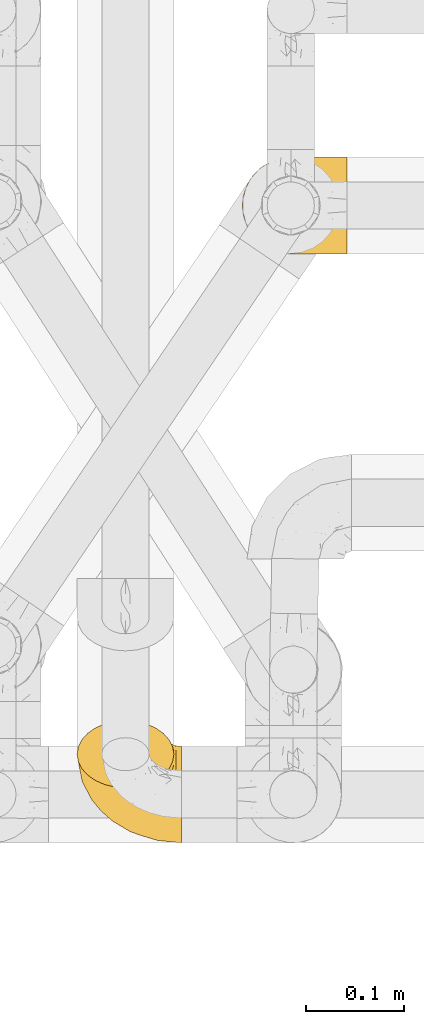
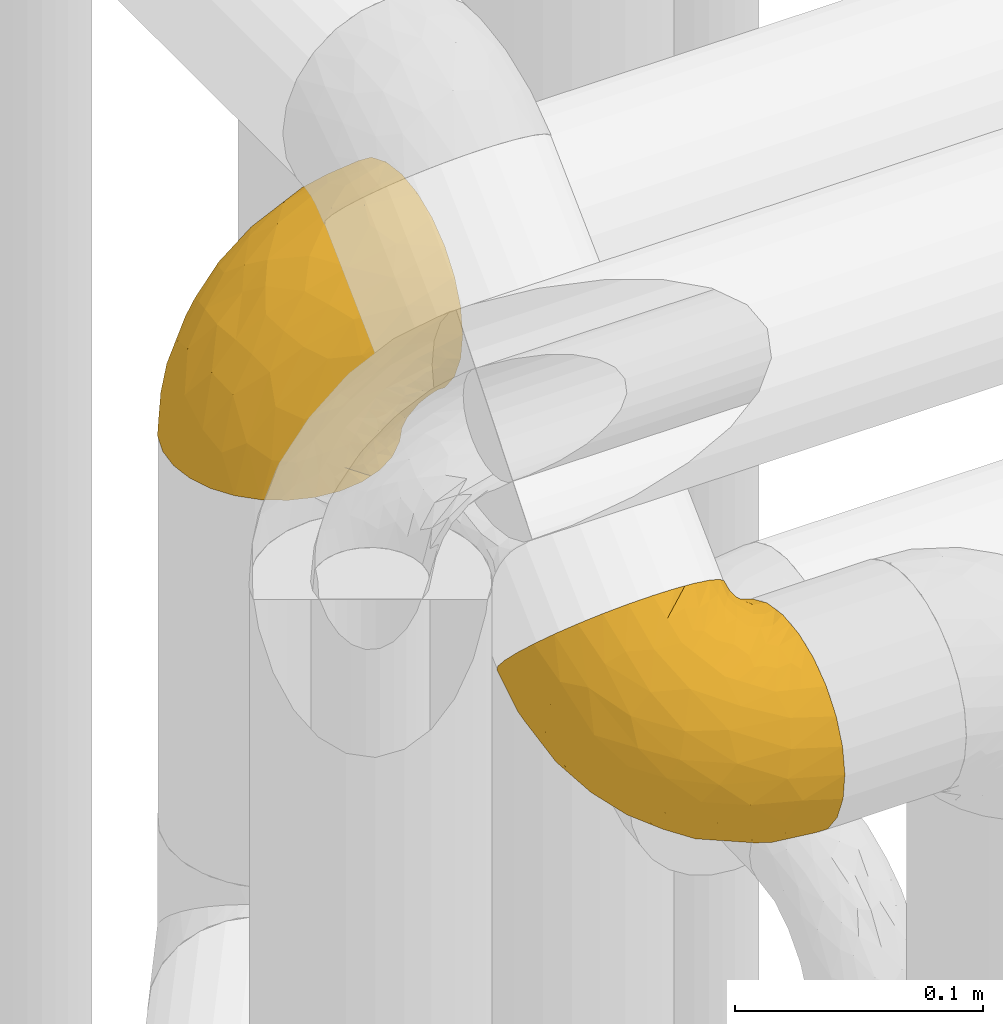
# One storey, part 385 of 827: 2 coverings.
"""IFC2X3 building model written with IfcOpenShell, lengths in millimetres."""

from ifc_helpers import new_model, entity, si_unit, converted_unit, derived_unit, direction, frame, origin, place, context, subcontext, project, spatial, faceted_brep, element, save


model = new_model("IFC2X3")

# Units and contexts
model_context = context("Model", 3, precision=0.01, world=origin(), true_north=direction((6.12303176911189e-17, 1.0)))
body_context = subcontext(model_context, "Body", "Model", "MODEL_VIEW")
ifc_project = project(units=[si_unit("LENGTHUNIT", "METRE", prefix="MILLI"), si_unit("AREAUNIT", "SQUARE_METRE"), si_unit("VOLUMEUNIT", "CUBIC_METRE"), converted_unit("PLANEANGLEUNIT", "DEGREE", entity("IfcRatioMeasure", 0.0174532925199433), si_unit("PLANEANGLEUNIT", "RADIAN"), dimensions=[0, 0, 0, 0, 0, 0, 0]), si_unit("MASSUNIT", "GRAM", prefix="KILO"), derived_unit("MASSDENSITYUNIT", [(si_unit("MASSUNIT", "GRAM", prefix="KILO"), 1), (si_unit("LENGTHUNIT", "METRE"), -3)]), derived_unit("MOMENTOFINERTIAUNIT", [(si_unit("LENGTHUNIT", "METRE"), 4)]), si_unit("TIMEUNIT", "SECOND"), si_unit("FREQUENCYUNIT", "HERTZ"), si_unit("THERMODYNAMICTEMPERATUREUNIT", "DEGREE_CELSIUS"), derived_unit("THERMALTRANSMITTANCEUNIT", [(si_unit("MASSUNIT", "GRAM", prefix="KILO"), 1), (si_unit("THERMODYNAMICTEMPERATUREUNIT", "KELVIN"), -1), (si_unit("TIMEUNIT", "SECOND"), -3)]), derived_unit("VOLUMETRICFLOWRATEUNIT", [(si_unit("LENGTHUNIT", "METRE"), 3), (si_unit("TIMEUNIT", "SECOND"), -1)]), derived_unit("MASSFLOWRATEUNIT", [(si_unit("MASSUNIT", "GRAM", prefix="KILO"), 1), (si_unit("TIMEUNIT", "SECOND"), -1)]), derived_unit("ROTATIONALFREQUENCYUNIT", [(si_unit("TIMEUNIT", "SECOND"), -1)]), si_unit("ELECTRICCURRENTUNIT", "AMPERE"), si_unit("ELECTRICVOLTAGEUNIT", "VOLT"), si_unit("POWERUNIT", "WATT"), si_unit("FORCEUNIT", "NEWTON", prefix="KILO"), si_unit("ILLUMINANCEUNIT", "LUX"), si_unit("LUMINOUSFLUXUNIT", "LUMEN"), si_unit("LUMINOUSINTENSITYUNIT", "CANDELA"), derived_unit("USERDEFINED", [(si_unit("MASSUNIT", "GRAM", prefix="KILO"), -1), (si_unit("LENGTHUNIT", "METRE"), -2), (si_unit("TIMEUNIT", "SECOND"), 3), (si_unit("LUMINOUSFLUXUNIT", "LUMEN"), 1)]), derived_unit("LINEARVELOCITYUNIT", [(si_unit("LENGTHUNIT", "METRE"), 1), (si_unit("TIMEUNIT", "SECOND"), -1)]), si_unit("PRESSUREUNIT", "PASCAL"), derived_unit("USERDEFINED", [(si_unit("LENGTHUNIT", "METRE"), -2), (si_unit("MASSUNIT", "GRAM", prefix="KILO"), 1), (si_unit("TIMEUNIT", "SECOND"), -2)]), derived_unit("LINEARFORCEUNIT", [(si_unit("MASSUNIT", "GRAM", prefix="KILO"), 1), (si_unit("LENGTHUNIT", "METRE"), 1), (si_unit("TIMEUNIT", "SECOND"), -2), (si_unit("LENGTHUNIT", "METRE"), -1)]), derived_unit("PLANARFORCEUNIT", [(si_unit("MASSUNIT", "GRAM", prefix="KILO"), 1), (si_unit("LENGTHUNIT", "METRE"), 1), (si_unit("TIMEUNIT", "SECOND"), -2), (si_unit("LENGTHUNIT", "METRE"), -2)])], contexts=[model_context])

# Site, building, storey
site_placement = place(None, origin())
site = spatial("IfcSite", under=ifc_project, at=site_placement, CompositionType="ELEMENT")
building_placement = place(site_placement, origin())
building = spatial("IfcBuilding", under=site, at=building_placement, CompositionType="ELEMENT")
storey_placement = place(building_placement, frame((0.0, 0.0, 28200.0)))
storey = spatial("IfcBuildingStorey", under=building, at=storey_placement, Name="08", CompositionType="ELEMENT", Elevation=28200.0)

# Coverings
covering_1_placement = place(storey_placement, frame((46945.29, 14184.93, 2546.4)))
element("IfcCovering", 1, at=covering_1_placement, inside=storey, Name=":ADSK_", ObjectType=":ADSK_", PredefinedType="INSULATION", context=body_context, shape_type="Brep", body=[
    faceted_brep([(50.75, 1.6, 1.6), (39.8, 2.83, 1.6), (29.41, 6.47, 1.6), (20.09, 12.32, 1.6), (12.31, 20.11, 1.6), (6.46, 29.43, 1.6), (2.83, 39.81, 1.6), (1.6, 50.75, 1.6), (2.83, 61.69, 1.6), (6.47, 72.08, 1.6), (12.32, 81.4, 1.6), (20.11, 89.18, 1.6), (29.43, 95.03, 1.6), (39.81, 98.66, 1.6), (50.75, 99.9, 1.6), (56.45, 99.25, 1.6), (61.69, 98.66, 1.6), (66.88, 96.84, 1.6), (72.08, 95.02, 1.6), (81.4, 89.17, 1.6), (89.18, 81.38, 1.6), (95.03, 72.06, 1.6), (98.66, 61.68, 1.6), (99.9, 50.75, 1.6), (98.66, 39.8, 1.6), (95.02, 29.41, 1.6), (89.17, 20.09, 1.6), (81.38, 12.31, 1.6), (72.06, 6.46, 1.6), (66.87, 4.64, 1.6), (61.68, 2.83, 1.6), (56.45, 2.24, 1.6), (53.6, 1.92, 1.6), (107.75, 63.47, 11.12), (107.75, 75.32, 16.03), (107.75, 80.41, 19.94), (107.75, 85.5, 23.84), (107.75, 89.4, 28.93), (107.75, 93.31, 34.02), (107.75, 95.77, 39.95), (107.75, 98.22, 45.87), (107.75, 99.14, 52.86), (107.75, 99.52, 55.73), (107.75, 99.9, 58.6), (107.75, 98.22, 71.32), (107.75, 93.31, 83.17), (107.75, 85.5, 93.35), (107.75, 75.32, 101.16), (107.75, 63.47, 106.07), (107.75, 50.75, 107.75), (107.75, 38.02, 106.07), (107.75, 26.17, 101.16), (107.75, 15.99, 93.35), (107.75, 8.18, 83.17), (107.75, 3.27, 71.32), (107.75, 1.6, 58.6), (107.75, 2.35, 52.86), (107.75, 3.27, 45.87), (107.75, 5.73, 39.95), (107.75, 8.18, 34.02), (107.75, 12.09, 28.93), (107.75, 15.99, 23.84), (107.75, 21.08, 19.94), (107.75, 26.17, 16.03), (107.75, 38.02, 11.12), (107.75, 50.75, 9.45), (39.38, 42.18, 81.82), (49.75, 28.42, 84.02), (57.38, 37.78, 93.05), (74.94, 50.75, 102.55), (85.97, 42.85, 104.83), (95.66, 50.75, 105.83), (67.82, 24.75, 91.87), (83.09, 33.81, 101.74), (89.16, 22.57, 97.07), (37.01, 7.18, 38.45), (43.46, 2.73, 22.17), (51.79, 3.09, 42.04), (85.58, 6.92, 77.69), (62.84, 11.58, 75.76), (62.77, 5.17, 62.11), (88.17, 2.71, 66.08), (85.93, 1.6, 54.26), (91.42, 1.6, 55.35), (96.91, 1.6, 56.44), (99.62, 1.6, 56.98), (102.33, 1.6, 57.52), (82.57, 14.18, 87.84), (32.75, 5.88, 19.41), (13.79, 41.06, 48.89), (6.77, 36.25, 26.34), (16.46, 28.62, 44.55), (55.08, 1.6, 23.41), (58.17, 1.6, 28.03), (61.26, 1.6, 32.65), (64.35, 1.6, 37.28), (67.44, 1.6, 41.9), (24.18, 10.85, 20.6), (23.37, 38.35, 63.36), (49.76, 9.6, 62.21), (9.84, 26.24, 19.94), (3.51, 50.75, 13.68), (55.75, 19.31, 80.85), (42.34, 16.41, 66.53), (37.78, 24.56, 71.06), (21.87, 50.75, 63.99), (33.61, 50.75, 75.73), (17.1, 18.47, 26.77), (51.28, 1.6, 4.31), (51.82, 1.6, 7.01), (52.9, 1.6, 12.43), (53.99, 1.6, 17.92), (28.01, 14.36, 43.43), (28.99, 20.64, 56.23), (69.9, 2.32, 54.97), (6.79, 50.75, 34.4), (72.06, 1.6, 44.99), (76.69, 1.6, 48.08), (81.31, 1.6, 51.17), (45.35, 50.75, 87.47), (34.79, 33.88, 74.55), (25.72, 29.24, 60.86), (14.33, 50.75, 49.19), (60.15, 50.75, 95.01), (62.38, 2.8, 10.27), (100.57, 2.48, 48.79), (91.06, 2.7, 45.16), (97.66, 3.2, 44.99), (97.55, 32.98, 6.17), (93.65, 24.67, 7.65), (66.85, 2.95, 21.59), (61.93, 2.19, 19.96), (101.4, 17.92, 21.0), (100.07, 12.02, 27.2), (101.36, 25.73, 14.83), (95.94, 16.63, 19.7), (96.3, 25.6, 10.93), (101.98, 36.72, 9.63), (85.88, 10.66, 19.97), (78.88, 6.87, 21.13), (82.8, 11.12, 14.14), (102.58, 10.31, 30.2), (82.88, 12.84, 8.12), (88.57, 17.38, 9.93), (88.67, 9.74, 24.62), (69.08, 4.63, 11.87), (102.19, 50.75, 7.15), (100.06, 42.52, 5.32), (70.56, 3.12, 26.68), (91.07, 17.58, 13.92), (77.56, 3.97, 30.67), (96.59, 5.94, 36.65), (86.38, 2.73, 42.89), (91.79, 6.23, 34.04), (81.71, 3.45, 36.6), (94.11, 10.84, 26.41), (76.09, 7.98, 10.07), (76.91, 7.33, 15.83), (81.44, 2.39, 41.99), (101.37, 75.76, 14.83), (94.12, 90.65, 26.4), (101.41, 83.57, 21.01), (95.96, 84.85, 19.71), (96.22, 71.05, 5.72), (66.85, 98.54, 21.6), (61.94, 99.3, 19.96), (58.17, 99.9, 28.03), (69.1, 96.86, 11.87), (88.58, 84.1, 9.93), (96.91, 99.9, 56.44), (102.33, 99.9, 57.52), (105.04, 99.9, 58.06), (82.9, 88.63, 8.13), (82.82, 90.36, 14.15), (97.66, 98.29, 44.99), (96.59, 95.55, 36.65), (100.07, 89.47, 27.21), (91.79, 95.26, 34.04), (102.58, 91.18, 30.2), (76.13, 93.49, 10.06), (76.93, 94.15, 15.83), (100.57, 99.01, 48.79), (86.38, 98.76, 42.89), (90.86, 98.85, 45.38), (52.9, 99.9, 12.43), (62.39, 98.69, 10.28), (101.98, 64.78, 9.64), (91.42, 99.9, 55.35), (85.93, 99.9, 54.26), (99.49, 62.91, 6.05), (51.82, 99.9, 7.01), (52.36, 99.9, 9.72), (61.26, 99.9, 32.65), (70.56, 98.37, 26.68), (91.09, 83.9, 13.92), (64.35, 99.9, 37.28), (77.6, 97.51, 30.66), (78.89, 94.62, 21.14), (81.71, 98.04, 36.59), (88.69, 91.73, 24.6), (53.99, 99.9, 17.92), (55.08, 99.9, 23.41), (96.31, 75.87, 10.93), (85.9, 90.83, 19.97), (81.45, 99.1, 41.99), (76.69, 99.9, 48.08), (81.31, 99.9, 51.17), (72.06, 99.9, 44.99), (67.44, 99.9, 41.9), (69.6, 99.09, 55.26), (85.97, 58.64, 104.83), (82.57, 87.31, 87.84), (63.16, 89.93, 75.91), (55.81, 82.22, 80.84), (67.81, 76.74, 91.87), (49.73, 73.12, 83.98), (32.55, 95.54, 19.16), (43.23, 98.7, 22.37), (88.17, 98.79, 66.08), (57.38, 63.71, 93.05), (83.08, 67.68, 101.74), (89.16, 78.92, 97.07), (85.58, 94.57, 77.69), (16.46, 72.88, 44.55), (6.77, 65.25, 26.34), (13.8, 60.44, 48.9), (37.71, 76.94, 70.99), (34.8, 67.61, 74.55), (36.83, 94.38, 37.8), (39.38, 59.31, 81.82), (17.12, 83.03, 26.77), (24.19, 90.66, 20.6), (28.89, 80.8, 56.15), (25.69, 72.22, 60.85), (51.77, 98.39, 42.06), (45.66, 92.31, 57.03), (23.39, 63.11, 63.4), (9.85, 75.27, 19.94), (28.11, 87.15, 43.59), (62.27, 96.03, 62.61), (42.35, 85.1, 66.52)], [[[0, 1, 2, 3, 4, 5, 6, 7, 8, 9, 10, 11, 12, 13, 14, 15, 16, 17, 18, 19, 20, 21, 22, 23, 24, 25, 26, 27, 28, 29, 30, 31, 32]], [[33, 34, 35, 36, 37, 38, 39, 40, 41, 42, 43, 44, 45, 46, 47, 48, 49, 50, 51, 52, 53, 54, 55, 56, 57, 58, 59, 60, 61, 62, 63, 64, 65]], [[66, 67, 68]], [[69, 70, 71]], [[68, 72, 73]], [[73, 72, 74]], [[75, 76, 77]], [[78, 79, 80]], [[51, 50, 73]], [[81, 82, 83, 84, 85, 86, 55]], [[52, 87, 53]], [[74, 52, 51]], [[2, 1, 88]], [[89, 90, 91]], [[77, 92, 93, 94, 95, 96]], [[55, 54, 81]], [[78, 53, 87]], [[5, 90, 6]], [[88, 76, 75]], [[97, 3, 2]], [[89, 91, 98]], [[99, 80, 79]], [[90, 5, 100]], [[74, 87, 52]], [[100, 5, 4]], [[90, 101, 6]], [[79, 102, 103]], [[102, 67, 104]], [[105, 98, 106]], [[107, 4, 3]], [[76, 0, 108, 109, 110, 111, 92]], [[107, 112, 113]], [[114, 77, 96]], [[89, 115, 90]], [[114, 96, 116, 117, 118, 82]], [[75, 97, 88]], [[119, 66, 68]], [[50, 71, 70]], [[100, 91, 90]], [[99, 77, 80]], [[102, 104, 103]], [[97, 107, 3]], [[80, 81, 78]], [[107, 97, 112]], [[68, 73, 70]], [[66, 98, 120]], [[78, 81, 54]], [[114, 81, 80]], [[53, 78, 54]], [[78, 87, 79]], [[102, 87, 72]], [[79, 103, 99]], [[4, 107, 100]], [[91, 100, 107]], [[88, 97, 2]], [[112, 97, 75]], [[99, 112, 75]], [[103, 104, 113]], [[91, 121, 98]], [[89, 105, 122, 115]], [[101, 90, 115]], [[101, 7, 6]], [[88, 1, 76]], [[0, 76, 1]], [[92, 77, 76]], [[73, 74, 51]], [[87, 74, 72]], [[81, 114, 82]], [[77, 114, 80]], [[87, 102, 79]], [[67, 102, 72]], [[68, 67, 72]], [[67, 120, 104]], [[120, 121, 104]], [[104, 121, 113]], [[121, 120, 98]], [[91, 107, 113]], [[91, 113, 121]], [[103, 113, 112]], [[106, 98, 66]], [[105, 89, 98]], [[106, 66, 119]], [[67, 66, 120]], [[68, 69, 123, 119]], [[50, 49, 71]], [[50, 70, 73]], [[112, 99, 103]], [[77, 99, 75]], [[69, 68, 70]], [[29, 124, 110]], [[84, 83, 125]], [[126, 82, 118]], [[59, 58, 127]], [[25, 128, 129]], [[130, 93, 131]], [[132, 62, 133]], [[134, 135, 136]], [[137, 65, 64]], [[64, 134, 137]], [[138, 139, 140]], [[111, 110, 124, 92]], [[134, 136, 137]], [[134, 64, 63]], [[141, 61, 60]], [[125, 58, 57]], [[142, 143, 140]], [[142, 26, 143]], [[127, 83, 82]], [[28, 124, 29]], [[108, 0, 32, 31, 30, 110, 109]], [[30, 29, 110]], [[135, 144, 138]], [[28, 145, 124]], [[57, 56, 55, 86, 85, 84]], [[146, 147, 23]], [[24, 23, 147]], [[25, 143, 26]], [[95, 94, 148]], [[24, 128, 25]], [[149, 138, 143]], [[124, 145, 131]], [[127, 58, 125]], [[150, 148, 139]], [[127, 126, 151]], [[151, 59, 127]], [[152, 151, 126]], [[153, 154, 155]], [[153, 133, 141]], [[145, 28, 27]], [[142, 156, 27]], [[157, 148, 130]], [[61, 133, 62]], [[134, 132, 135]], [[147, 128, 24]], [[65, 137, 146]], [[146, 137, 147]], [[128, 137, 136]], [[137, 128, 147]], [[128, 136, 129]], [[149, 129, 136]], [[25, 129, 143]], [[158, 152, 117]], [[152, 118, 117]], [[153, 151, 152]], [[158, 116, 154]], [[144, 150, 138]], [[153, 152, 158]], [[133, 153, 155]], [[133, 155, 132]], [[60, 151, 141]], [[135, 132, 155]], [[134, 63, 132]], [[144, 135, 155]], [[135, 138, 149]], [[155, 154, 144]], [[150, 154, 96]], [[154, 150, 144]], [[148, 94, 130]], [[82, 126, 127]], [[118, 152, 126]], [[150, 96, 95]], [[139, 148, 157]], [[150, 95, 148]], [[93, 92, 131]], [[130, 145, 156]], [[130, 94, 93]], [[84, 125, 57]], [[127, 125, 83]], [[140, 139, 157]], [[150, 139, 138]], [[140, 157, 142]], [[138, 140, 143]], [[156, 142, 157]], [[27, 26, 142]], [[130, 156, 157]], [[145, 27, 156]], [[132, 63, 62]], [[124, 131, 92]], [[130, 131, 145]], [[129, 149, 143]], [[135, 149, 136]], [[141, 133, 61]], [[60, 59, 151]], [[141, 151, 153]], [[116, 96, 154]], [[153, 158, 154]], [[158, 117, 116]], [[34, 33, 159]], [[160, 161, 162]], [[22, 21, 163]], [[164, 165, 166]], [[19, 18, 167]], [[168, 21, 20]], [[42, 41, 40, 169, 170, 171, 43]], [[172, 173, 168]], [[174, 38, 175]], [[176, 177, 178]], [[179, 164, 180]], [[40, 181, 169]], [[182, 183, 175]], [[17, 184, 185]], [[65, 146, 186]], [[187, 174, 188]], [[23, 22, 189]], [[174, 39, 38]], [[15, 14, 190, 191, 184, 16]], [[181, 40, 39]], [[192, 193, 164]], [[194, 163, 168]], [[33, 186, 159]], [[180, 173, 172]], [[195, 196, 193]], [[18, 185, 167]], [[173, 180, 197]], [[198, 199, 196]], [[200, 201, 185, 184]], [[184, 17, 16]], [[18, 17, 185]], [[202, 159, 186]], [[194, 168, 203]], [[189, 163, 202]], [[204, 205, 182]], [[187, 181, 174]], [[160, 177, 176]], [[206, 183, 182]], [[206, 182, 205]], [[201, 165, 185]], [[165, 164, 167]], [[172, 179, 180]], [[202, 194, 162]], [[176, 161, 160]], [[65, 186, 33]], [[163, 189, 22]], [[175, 177, 182]], [[174, 183, 188]], [[177, 198, 204]], [[199, 160, 162]], [[198, 207, 204]], [[175, 38, 37]], [[198, 177, 160]], [[178, 177, 175]], [[176, 35, 161]], [[34, 159, 161]], [[162, 161, 159]], [[202, 162, 159]], [[199, 162, 203]], [[196, 199, 203]], [[198, 160, 199]], [[193, 197, 180]], [[208, 198, 196]], [[188, 183, 206]], [[175, 183, 174]], [[193, 192, 195]], [[195, 208, 196]], [[197, 196, 203]], [[180, 164, 193]], [[168, 163, 21]], [[166, 165, 201]], [[166, 192, 164]], [[189, 202, 186]], [[186, 146, 189]], [[23, 189, 146]], [[174, 181, 39]], [[169, 181, 187]], [[196, 197, 193]], [[173, 203, 168]], [[203, 173, 197]], [[172, 168, 20]], [[20, 19, 172]], [[179, 172, 19]], [[19, 167, 179]], [[164, 179, 167]], [[35, 176, 36]], [[35, 34, 161]], [[185, 165, 167]], [[162, 194, 203]], [[163, 194, 202]], [[176, 178, 36]], [[37, 36, 178]], [[175, 37, 178]], [[177, 204, 182]], [[207, 198, 208]], [[207, 205, 204]], [[209, 188, 206, 205, 207, 208]], [[48, 210, 71]], [[211, 212, 213]], [[214, 213, 215]], [[216, 217, 13]], [[218, 43, 171, 170, 169, 187, 188]], [[219, 220, 214]], [[47, 46, 221]], [[210, 48, 220]], [[211, 222, 212]], [[222, 45, 44]], [[221, 220, 47]], [[47, 220, 48]], [[221, 211, 214]], [[223, 224, 225]], [[211, 46, 45]], [[226, 227, 215]], [[43, 218, 44]], [[217, 216, 228]], [[219, 215, 229]], [[14, 13, 217]], [[224, 9, 8]], [[10, 230, 11]], [[11, 231, 12]], [[232, 223, 233]], [[234, 208, 195, 192, 166, 201]], [[235, 234, 228]], [[222, 44, 218]], [[106, 229, 236]], [[224, 237, 9]], [[231, 238, 228]], [[9, 237, 10]], [[115, 224, 101]], [[239, 234, 235]], [[231, 11, 230]], [[223, 230, 237]], [[224, 8, 101]], [[223, 236, 233]], [[225, 115, 122, 105]], [[216, 12, 231]], [[209, 234, 239]], [[210, 219, 69]], [[219, 214, 215]], [[229, 119, 219]], [[209, 218, 188]], [[239, 212, 222]], [[239, 222, 218]], [[45, 222, 211]], [[235, 212, 239]], [[213, 212, 240]], [[223, 237, 224]], [[230, 10, 237]], [[238, 231, 230]], [[216, 231, 228]], [[232, 230, 223]], [[235, 238, 240]], [[115, 225, 224]], [[233, 236, 227]], [[8, 7, 101]], [[234, 209, 208]], [[218, 209, 239]], [[217, 228, 234]], [[13, 12, 216]], [[234, 201, 217]], [[217, 201, 200, 184, 191, 190, 14]], [[211, 221, 46]], [[220, 221, 214]], [[71, 210, 69]], [[71, 49, 48]], [[219, 210, 220]], [[226, 215, 213]], [[211, 213, 214]], [[226, 213, 240]], [[215, 227, 229]], [[232, 240, 238]], [[233, 227, 226]], [[232, 233, 226]], [[236, 223, 225]], [[240, 232, 226]], [[232, 238, 230]], [[225, 105, 236]], [[236, 105, 106]], [[236, 229, 227]], [[123, 69, 219, 119]], [[106, 119, 229]], [[238, 235, 228]], [[212, 235, 240]]]),
])
covering_2_placement = place(storey_placement, frame((46777.25, 13586.1, 2759.05)))
element("IfcCovering", 2, at=covering_2_placement, inside=storey, Name=":ADSK_", ObjectType=":ADSK_", PredefinedType="INSULATION", context=body_context, shape_type="Brep", body=[
    faceted_brep([(50.75, 125.88, 55.02), (39.8, 125.02, 55.91), (29.41, 122.5, 58.52), (20.09, 118.42, 62.73), (12.31, 113.01, 68.33), (6.46, 106.54, 75.03), (2.83, 99.32, 82.5), (1.6, 91.72, 90.36), (2.83, 84.11, 98.22), (6.47, 76.89, 105.69), (12.32, 70.42, 112.39), (20.11, 65.01, 117.99), (29.43, 60.94, 122.2), (39.81, 58.41, 124.81), (50.75, 57.56, 125.69), (56.45, 58.0, 125.23), (61.69, 58.42, 124.81), (66.88, 59.68, 123.5), (72.08, 60.94, 122.19), (81.4, 65.02, 117.98), (89.18, 70.43, 112.38), (95.03, 76.9, 105.68), (98.66, 84.12, 98.21), (99.9, 91.72, 90.36), (98.66, 99.32, 82.49), (95.02, 106.55, 75.02), (89.17, 113.02, 68.32), (81.38, 118.43, 62.72), (72.06, 122.5, 58.52), (66.87, 123.76, 57.21), (61.68, 125.03, 55.9), (56.45, 125.43, 55.48), (53.6, 125.66, 55.25), (107.75, 76.03, 92.88), (107.75, 64.26, 97.99), (107.75, 57.92, 98.94), (107.75, 51.57, 99.88), (107.75, 45.2, 99.15), (107.75, 38.82, 98.42), (107.75, 32.85, 96.07), (107.75, 26.89, 93.71), (107.75, 21.22, 89.52), (107.75, 18.9, 87.8), (107.75, 16.58, 86.08), (107.75, 8.59, 76.03), (107.75, 3.49, 64.26), (107.75, 1.6, 51.57), (107.75, 3.05, 38.82), (107.75, 7.76, 26.89), (107.75, 15.4, 16.58), (107.75, 25.45, 8.59), (107.75, 37.22, 3.49), (107.75, 49.91, 1.6), (107.75, 62.65, 3.05), (107.75, 74.59, 7.76), (107.75, 84.9, 15.4), (107.75, 88.5, 19.93), (107.75, 92.88, 25.45), (107.75, 95.44, 31.33), (107.75, 97.99, 37.22), (107.75, 98.94, 43.56), (107.75, 99.88, 49.91), (107.75, 99.15, 56.28), (107.75, 98.42, 62.65), (107.75, 93.71, 74.59), (107.75, 86.08, 84.9), (39.38, 39.99, 28.44), (49.75, 47.98, 17.01), (57.38, 34.98, 17.46), (74.94, 19.14, 20.19), (85.97, 22.98, 12.92), (95.66, 16.78, 17.91), (67.82, 44.88, 8.92), (83.09, 31.49, 8.57), (89.16, 42.66, 3.73), (37.01, 95.5, 33.42), (43.46, 110.3, 41.53), (51.79, 95.76, 27.98), (85.58, 67.47, 5.96), (62.84, 65.62, 10.65), (62.77, 79.89, 15.53), (88.17, 78.75, 11.0), (85.93, 88.02, 18.42), (91.42, 87.23, 17.66), (96.91, 86.45, 16.9), (99.62, 86.06, 16.52), (102.33, 85.67, 16.15), (82.57, 55.13, 4.12), (32.75, 110.1, 45.72), (13.79, 64.45, 50.52), (6.77, 84.0, 62.73), (16.46, 76.21, 44.6), (55.08, 110.2, 39.86), (58.17, 106.87, 36.64), (61.26, 103.55, 33.43), (64.35, 100.23, 30.22), (67.44, 96.9, 27.0), (24.18, 105.79, 48.46), (23.37, 55.93, 38.52), (49.76, 76.74, 18.64), (9.84, 95.56, 59.99), (3.51, 83.03, 81.96), (55.75, 56.59, 12.67), (42.34, 68.9, 20.53), (37.78, 59.97, 23.25), (21.87, 46.86, 46.99), (33.61, 38.42, 38.83), (17.1, 96.05, 49.66), (51.28, 123.93, 53.13), (51.82, 121.98, 51.25), (52.9, 118.09, 47.48), (53.99, 114.14, 43.67), (28.01, 86.94, 35.12), (28.99, 73.37, 30.74), (69.9, 87.0, 18.44), (6.79, 68.14, 67.56), (72.06, 94.68, 24.86), (76.69, 92.46, 22.71), (81.31, 90.24, 20.56), (45.35, 29.98, 30.67), (34.79, 50.99, 27.53), (25.72, 64.06, 33.7), (14.33, 57.5, 57.27), (60.15, 24.56, 25.43), (62.38, 118.81, 49.86), (100.57, 91.34, 22.85), (91.06, 93.79, 25.53), (97.66, 93.57, 26.01), (97.55, 100.77, 74.4), (93.65, 105.49, 67.4), (66.85, 110.56, 42.1), (61.93, 112.26, 42.68), (101.4, 100.58, 53.27), (100.07, 100.22, 44.72), (101.36, 99.59, 63.17), (95.94, 102.41, 53.24), (96.3, 102.48, 65.79), (101.98, 95.69, 74.68), (85.88, 106.37, 48.76), (78.88, 108.17, 45.23), (82.8, 110.24, 53.15), (102.58, 99.26, 41.4), (82.88, 113.37, 58.57), (88.57, 108.92, 60.58), (88.67, 103.67, 44.87), (69.08, 116.39, 50.06), (102.19, 87.73, 86.5), (100.06, 94.76, 81.85), (70.56, 106.78, 38.68), (91.07, 105.92, 57.94), (77.56, 103.33, 36.51), (96.59, 97.65, 33.78), (86.38, 95.4, 27.14), (91.79, 99.33, 35.8), (81.71, 99.43, 32.02), (94.11, 101.62, 44.42), (76.09, 115.35, 53.72), (76.91, 111.66, 49.24), (81.44, 96.28, 27.51), (101.37, 64.82, 99.14), (94.12, 46.15, 101.8), (101.41, 54.95, 100.46), (95.96, 55.0, 102.29), (96.22, 74.64, 102.08), (66.85, 44.12, 110.81), (61.94, 44.77, 112.5), (58.17, 38.55, 107.32), (69.1, 52.28, 116.37), (88.58, 62.55, 108.54), (105.04, 16.96, 86.45), (96.91, 18.13, 87.57), (102.33, 17.35, 86.82), (82.9, 60.69, 113.05), (82.82, 55.16, 110.11), (97.66, 27.48, 94.38), (96.59, 35.37, 98.2), (102.58, 43.05, 99.55), (76.13, 55.93, 115.2), (76.93, 51.31, 111.67), (100.57, 24.24, 92.26), (86.38, 28.66, 96.18), (90.86, 26.81, 94.51), (52.9, 49.77, 118.16), (62.39, 52.15, 118.79), (101.98, 76.18, 94.86), (91.42, 18.91, 88.33), (85.93, 19.7, 89.09), (99.49, 80.07, 96.01), (51.82, 53.66, 121.93), (52.36, 51.71, 120.04), (61.26, 35.23, 104.11), (70.56, 40.58, 107.16), (91.09, 59.81, 105.63), (64.35, 31.9, 100.89), (77.6, 38.32, 103.77), (78.89, 47.17, 108.32), (81.71, 33.69, 100.04), (88.69, 46.69, 103.83), (53.99, 45.82, 114.35), (55.08, 41.88, 110.53), (96.31, 67.55, 101.93), (85.9, 50.65, 106.4), (81.45, 29.07, 97.05), (76.69, 24.14, 93.39), (91.79, 37.45, 99.81), (100.07, 46.39, 100.4), (81.31, 21.92, 91.24), (72.06, 26.36, 95.53), (67.44, 28.58, 97.68), (69.6, 19.53, 87.81), (85.97, 12.01, 24.28), (82.57, 4.3, 56.7), (63.16, 11.05, 66.88), (55.81, 12.87, 57.9), (67.81, 8.75, 46.3), (49.73, 16.94, 49.18), (32.55, 47.95, 110.35), (43.23, 43.45, 110.39), (88.17, 11.97, 80.08), (57.38, 16.95, 36.11), (83.08, 7.94, 32.93), (89.16, 3.49, 44.25), (85.58, 6.55, 68.97), (16.46, 45.45, 76.42), (6.77, 63.84, 83.58), (13.8, 50.97, 64.45), (37.71, 23.62, 60.96), (34.8, 27.55, 51.78), (36.83, 35.36, 96.56), (39.38, 28.09, 40.76), (17.12, 51.18, 96.07), (24.19, 50.31, 105.84), (28.89, 31.61, 74.05), (25.69, 34.19, 64.61), (51.77, 29.51, 96.48), (45.66, 22.98, 81.71), (23.39, 38.69, 56.29), (9.85, 61.48, 95.23), (28.11, 36.23, 87.34), (62.27, 16.37, 80.51), (42.35, 21.16, 69.93)], [[[0, 1, 2, 3, 4, 5, 6, 7, 8, 9, 10, 11, 12, 13, 14, 15, 16, 17, 18, 19, 20, 21, 22, 23, 24, 25, 26, 27, 28, 29, 30, 31, 32]], [[33, 34, 35, 36, 37, 38, 39, 40, 41, 42, 43, 44, 45, 46, 47, 48, 49, 50, 51, 52, 53, 54, 55, 56, 57, 58, 59, 60, 61, 62, 63, 64, 65]], [[66, 67, 68]], [[69, 70, 71]], [[68, 72, 73]], [[73, 72, 74]], [[75, 76, 77]], [[78, 79, 80]], [[51, 50, 73]], [[81, 82, 83, 84, 85, 86, 55]], [[52, 87, 53]], [[74, 52, 51]], [[2, 1, 88]], [[89, 90, 91]], [[77, 92, 93, 94, 95, 96]], [[55, 54, 81]], [[78, 53, 87]], [[5, 90, 6]], [[88, 76, 75]], [[97, 3, 2]], [[89, 91, 98]], [[99, 80, 79]], [[90, 5, 100]], [[74, 87, 52]], [[100, 5, 4]], [[90, 101, 6]], [[79, 102, 103]], [[102, 67, 104]], [[105, 98, 106]], [[107, 4, 3]], [[76, 0, 108, 109, 110, 111, 92]], [[107, 112, 113]], [[114, 77, 96]], [[89, 115, 90]], [[114, 96, 116, 117, 118, 82]], [[75, 97, 88]], [[119, 66, 68]], [[50, 71, 70]], [[100, 91, 90]], [[99, 77, 80]], [[102, 104, 103]], [[97, 107, 3]], [[80, 81, 78]], [[107, 97, 112]], [[68, 73, 70]], [[66, 98, 120]], [[78, 81, 54]], [[114, 81, 80]], [[53, 78, 54]], [[78, 87, 79]], [[102, 87, 72]], [[79, 103, 99]], [[4, 107, 100]], [[91, 100, 107]], [[88, 97, 2]], [[112, 97, 75]], [[99, 112, 75]], [[103, 104, 113]], [[91, 121, 98]], [[89, 105, 122, 115]], [[101, 90, 115]], [[101, 7, 6]], [[88, 1, 76]], [[0, 76, 1]], [[92, 77, 76]], [[73, 74, 51]], [[87, 74, 72]], [[81, 114, 82]], [[77, 114, 80]], [[87, 102, 79]], [[67, 102, 72]], [[68, 67, 72]], [[67, 120, 104]], [[120, 121, 104]], [[104, 121, 113]], [[121, 120, 98]], [[91, 107, 113]], [[91, 113, 121]], [[103, 113, 112]], [[106, 98, 66]], [[105, 89, 98]], [[106, 66, 119]], [[67, 66, 120]], [[68, 69, 123, 119]], [[50, 49, 71]], [[50, 70, 73]], [[112, 99, 103]], [[77, 99, 75]], [[69, 68, 70]], [[29, 124, 110]], [[84, 83, 125]], [[126, 82, 118]], [[59, 58, 127]], [[25, 128, 129]], [[130, 93, 131]], [[132, 62, 133]], [[134, 135, 136]], [[137, 65, 64]], [[64, 134, 137]], [[138, 139, 140]], [[111, 110, 124, 92]], [[134, 136, 137]], [[134, 64, 63]], [[133, 61, 141]], [[125, 58, 57]], [[142, 143, 140]], [[142, 26, 143]], [[127, 83, 82]], [[28, 124, 29]], [[108, 0, 32, 31, 30, 110, 109]], [[30, 29, 110]], [[135, 144, 138]], [[28, 145, 124]], [[57, 56, 55, 86, 85, 84]], [[146, 147, 23]], [[24, 23, 147]], [[25, 143, 26]], [[95, 94, 148]], [[24, 128, 25]], [[149, 138, 143]], [[124, 145, 131]], [[127, 58, 125]], [[150, 148, 139]], [[127, 126, 151]], [[151, 59, 127]], [[152, 151, 126]], [[153, 154, 155]], [[153, 133, 141]], [[145, 28, 27]], [[142, 156, 27]], [[157, 148, 130]], [[61, 133, 62]], [[134, 132, 135]], [[147, 128, 24]], [[65, 137, 146]], [[146, 137, 147]], [[128, 137, 136]], [[137, 128, 147]], [[128, 136, 129]], [[149, 129, 136]], [[25, 129, 143]], [[158, 152, 117]], [[152, 118, 117]], [[153, 151, 152]], [[158, 116, 154]], [[144, 150, 138]], [[153, 152, 158]], [[133, 153, 155]], [[133, 155, 132]], [[141, 61, 60]], [[135, 132, 155]], [[134, 63, 132]], [[144, 135, 155]], [[135, 138, 149]], [[155, 154, 144]], [[150, 154, 96]], [[154, 150, 144]], [[148, 94, 130]], [[82, 126, 127]], [[118, 152, 126]], [[150, 96, 95]], [[139, 148, 157]], [[150, 95, 148]], [[93, 92, 131]], [[130, 145, 156]], [[130, 94, 93]], [[84, 125, 57]], [[127, 125, 83]], [[140, 139, 157]], [[150, 139, 138]], [[140, 157, 142]], [[138, 140, 143]], [[156, 142, 157]], [[27, 26, 142]], [[130, 156, 157]], [[145, 27, 156]], [[132, 63, 62]], [[124, 131, 92]], [[130, 131, 145]], [[129, 149, 143]], [[135, 149, 136]], [[60, 151, 141]], [[59, 151, 60]], [[141, 151, 153]], [[116, 96, 154]], [[153, 158, 154]], [[158, 117, 116]], [[34, 33, 159]], [[160, 161, 162]], [[22, 21, 163]], [[164, 165, 166]], [[19, 18, 167]], [[168, 21, 20]], [[169, 43, 42, 41, 40, 170, 171]], [[172, 173, 168]], [[174, 38, 175]], [[176, 37, 36]], [[177, 164, 178]], [[40, 179, 170]], [[180, 181, 175]], [[17, 182, 183]], [[65, 146, 184]], [[185, 174, 186]], [[23, 22, 187]], [[174, 39, 38]], [[15, 14, 188, 189, 182, 16]], [[179, 40, 39]], [[190, 191, 164]], [[192, 163, 168]], [[33, 184, 159]], [[178, 173, 172]], [[193, 194, 191]], [[18, 183, 167]], [[173, 178, 195]], [[196, 197, 194]], [[198, 199, 183, 182]], [[182, 17, 16]], [[18, 17, 183]], [[200, 159, 184]], [[192, 168, 201]], [[187, 163, 200]], [[202, 203, 180]], [[185, 179, 174]], [[160, 204, 205]], [[206, 181, 180]], [[206, 180, 203]], [[199, 165, 183]], [[165, 164, 167]], [[172, 177, 178]], [[200, 192, 162]], [[205, 161, 160]], [[65, 184, 33]], [[163, 187, 22]], [[175, 204, 180]], [[174, 181, 186]], [[204, 196, 202]], [[197, 160, 162]], [[196, 207, 202]], [[205, 204, 176]], [[196, 204, 160]], [[176, 204, 175]], [[205, 35, 161]], [[34, 159, 161]], [[162, 161, 159]], [[200, 162, 159]], [[197, 162, 201]], [[194, 197, 201]], [[196, 160, 197]], [[191, 195, 178]], [[208, 196, 194]], [[186, 181, 206]], [[175, 181, 174]], [[191, 190, 193]], [[193, 208, 194]], [[195, 194, 201]], [[178, 164, 191]], [[168, 163, 21]], [[166, 165, 199]], [[166, 190, 164]], [[187, 200, 184]], [[184, 146, 187]], [[23, 187, 146]], [[174, 179, 39]], [[170, 179, 185]], [[194, 195, 191]], [[173, 201, 168]], [[201, 173, 195]], [[172, 168, 20]], [[20, 19, 172]], [[177, 172, 19]], [[19, 167, 177]], [[164, 177, 167]], [[35, 205, 36]], [[35, 34, 161]], [[183, 165, 167]], [[162, 192, 201]], [[163, 192, 200]], [[175, 38, 37]], [[205, 176, 36]], [[175, 37, 176]], [[204, 202, 180]], [[207, 196, 208]], [[207, 203, 202]], [[209, 186, 206, 203, 207, 208]], [[48, 210, 71]], [[211, 212, 213]], [[214, 213, 215]], [[216, 217, 13]], [[218, 43, 169, 171, 170, 185, 186]], [[219, 220, 214]], [[47, 46, 221]], [[210, 48, 220]], [[211, 222, 212]], [[222, 45, 44]], [[221, 220, 47]], [[47, 220, 48]], [[221, 211, 214]], [[223, 224, 225]], [[211, 46, 45]], [[226, 227, 215]], [[43, 218, 44]], [[217, 216, 228]], [[219, 215, 229]], [[14, 13, 217]], [[224, 9, 8]], [[10, 230, 11]], [[11, 231, 12]], [[232, 223, 233]], [[234, 208, 193, 190, 166, 199]], [[235, 234, 228]], [[222, 44, 218]], [[106, 229, 236]], [[224, 237, 9]], [[231, 238, 228]], [[9, 237, 10]], [[115, 224, 101]], [[239, 234, 235]], [[231, 11, 230]], [[223, 230, 237]], [[224, 8, 101]], [[223, 236, 233]], [[225, 115, 122, 105]], [[216, 12, 231]], [[209, 234, 239]], [[210, 219, 69]], [[219, 214, 215]], [[229, 119, 219]], [[209, 218, 186]], [[239, 212, 222]], [[239, 222, 218]], [[45, 222, 211]], [[235, 212, 239]], [[213, 212, 240]], [[223, 237, 224]], [[230, 10, 237]], [[238, 231, 230]], [[216, 231, 228]], [[232, 230, 223]], [[235, 238, 240]], [[115, 225, 224]], [[233, 236, 227]], [[8, 7, 101]], [[234, 209, 208]], [[218, 209, 239]], [[217, 228, 234]], [[13, 12, 216]], [[234, 199, 217]], [[217, 199, 198, 182, 189, 188, 14]], [[211, 221, 46]], [[220, 221, 214]], [[71, 210, 69]], [[71, 49, 48]], [[219, 210, 220]], [[226, 215, 213]], [[211, 213, 214]], [[226, 213, 240]], [[215, 227, 229]], [[232, 240, 238]], [[233, 227, 226]], [[232, 233, 226]], [[236, 223, 225]], [[240, 232, 226]], [[232, 238, 230]], [[225, 105, 236]], [[236, 105, 106]], [[236, 229, 227]], [[123, 69, 219, 119]], [[106, 119, 229]], [[238, 235, 228]], [[212, 235, 240]]]),
])

save(model, "model.ifc")
